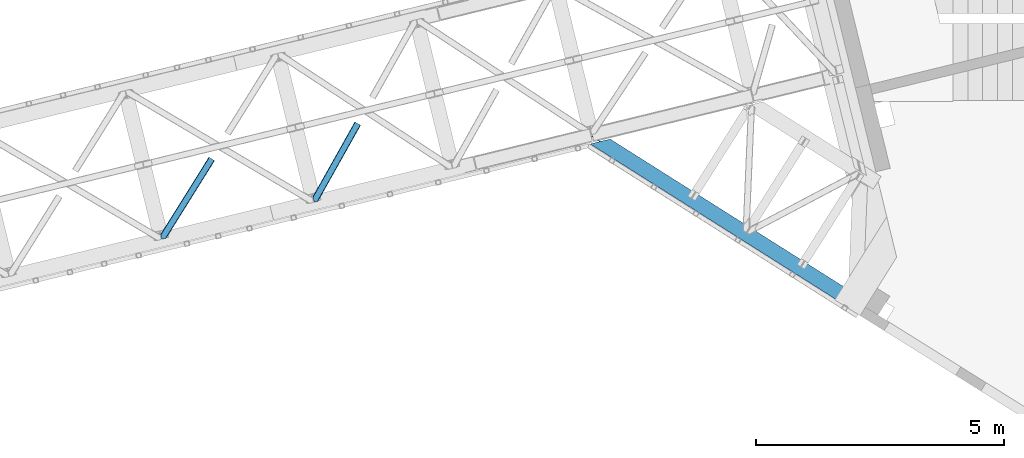
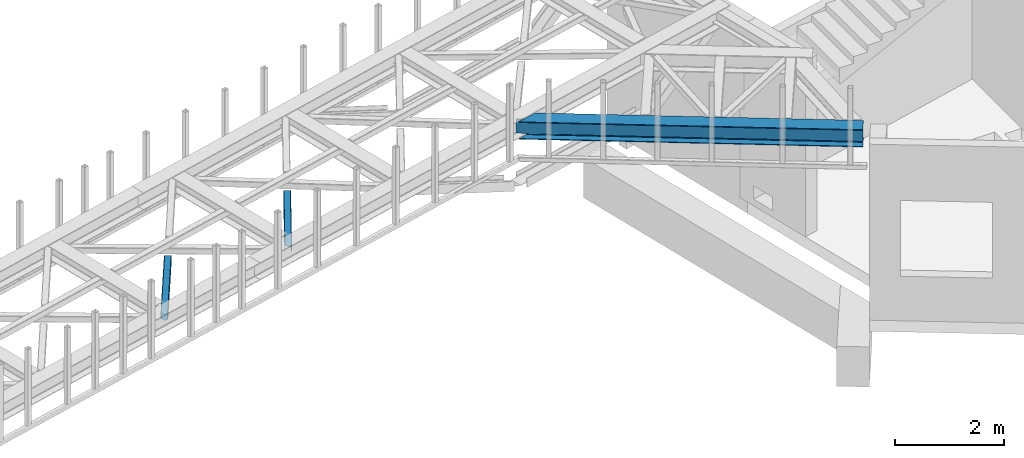
# One storey, part 48 of 66: 2 members, 1 beam.
"""IFC4 building model written with IfcOpenShell, lengths in millimetres."""

from ifc_helpers import new_model, entity, si_unit, converted_unit, derived_unit, direction, frame, origin, place, context, subcontext, project, spatial, triangles, polygons, material, type_object, element, save


model = new_model("IFC4")

# Units and contexts
model_context = context("Model", 3, precision=0.01, world=origin(), true_north=direction((6.12303176911189e-17, 1.0)))
plan_context = context("Plan", 3, precision=0.01, world=origin(), true_north=direction((6.12303176911189e-17, 1.0)))
body_context = subcontext(model_context, "Body", "Model", "MODEL_VIEW")
ifc_project = project(units=[si_unit("LENGTHUNIT", "METRE", prefix="MILLI"), si_unit("AREAUNIT", "SQUARE_METRE"), si_unit("VOLUMEUNIT", "CUBIC_METRE"), converted_unit("PLANEANGLEUNIT", "DEGREE", entity("IfcRatioMeasure", 0.0174532925199433), si_unit("PLANEANGLEUNIT", "RADIAN"), dimensions=[0, 0, 0, 0, 0, 0, 0]), si_unit("MASSUNIT", "GRAM", prefix="KILO"), derived_unit("MASSDENSITYUNIT", [(si_unit("MASSUNIT", "GRAM", prefix="KILO"), 1), (si_unit("LENGTHUNIT", "METRE"), -3)]), derived_unit("MOMENTOFINERTIAUNIT", [(si_unit("LENGTHUNIT", "METRE"), 4)]), si_unit("TIMEUNIT", "SECOND"), si_unit("FREQUENCYUNIT", "HERTZ"), si_unit("THERMODYNAMICTEMPERATUREUNIT", "DEGREE_CELSIUS"), derived_unit("THERMALTRANSMITTANCEUNIT", [(si_unit("MASSUNIT", "GRAM", prefix="KILO"), 1), (si_unit("THERMODYNAMICTEMPERATUREUNIT", "KELVIN"), -1), (si_unit("TIMEUNIT", "SECOND"), -3)]), derived_unit("VOLUMETRICFLOWRATEUNIT", [(si_unit("LENGTHUNIT", "METRE"), 3), (si_unit("TIMEUNIT", "SECOND"), -1)]), derived_unit("MASSFLOWRATEUNIT", [(si_unit("MASSUNIT", "GRAM", prefix="KILO"), 1), (si_unit("TIMEUNIT", "SECOND"), -1)]), derived_unit("ROTATIONALFREQUENCYUNIT", [(si_unit("TIMEUNIT", "SECOND"), -1)]), si_unit("ELECTRICCURRENTUNIT", "AMPERE"), si_unit("ELECTRICVOLTAGEUNIT", "VOLT"), si_unit("POWERUNIT", "WATT"), si_unit("FORCEUNIT", "NEWTON", prefix="KILO"), si_unit("ILLUMINANCEUNIT", "LUX"), si_unit("LUMINOUSFLUXUNIT", "LUMEN"), si_unit("LUMINOUSINTENSITYUNIT", "CANDELA"), derived_unit("USERDEFINED", [(si_unit("MASSUNIT", "GRAM", prefix="KILO"), -1), (si_unit("LENGTHUNIT", "METRE"), -2), (si_unit("TIMEUNIT", "SECOND"), 3), (si_unit("LUMINOUSFLUXUNIT", "LUMEN"), 1)]), derived_unit("LINEARVELOCITYUNIT", [(si_unit("LENGTHUNIT", "METRE"), 1), (si_unit("TIMEUNIT", "SECOND"), -1)]), si_unit("PRESSUREUNIT", "PASCAL"), derived_unit("USERDEFINED", [(si_unit("LENGTHUNIT", "METRE"), -2), (si_unit("MASSUNIT", "GRAM", prefix="KILO"), 1), (si_unit("TIMEUNIT", "SECOND"), -2)]), derived_unit("LINEARFORCEUNIT", [(si_unit("MASSUNIT", "GRAM", prefix="KILO"), 1), (si_unit("LENGTHUNIT", "METRE"), 1), (si_unit("TIMEUNIT", "SECOND"), -2), (si_unit("LENGTHUNIT", "METRE"), -1)]), derived_unit("PLANARFORCEUNIT", [(si_unit("MASSUNIT", "GRAM", prefix="KILO"), 1), (si_unit("LENGTHUNIT", "METRE"), 1), (si_unit("TIMEUNIT", "SECOND"), -2), (si_unit("LENGTHUNIT", "METRE"), -2)])], contexts=[model_context, plan_context])

# Site, building, storey
site_placement = place(None, origin())
site = spatial("IfcSite", under=ifc_project, at=site_placement, CompositionType="ELEMENT")
building_placement = place(site_placement, origin())
building = spatial("IfcBuilding", under=site, at=building_placement, CompositionType="ELEMENT")
storey_placement = place(building_placement, frame((0.0, 0.0, 19800.0)))
storey = spatial("IfcBuildingStorey", under=building, at=storey_placement, Name="06", CompositionType="ELEMENT", Elevation=19800.0)

# Beam
ifc_material = material(Name="Metal painted (White)")
beam_type = type_object("IfcBeamType", PredefinedType="BEAM")
beam_placement = place(storey_placement, frame((-5441.52, 12718.9, 3716.0)))
element("IfcBeam", 1, at=beam_placement, inside=storey, type_object=beam_type, material=ifc_material, ObjectType="Steel Beam", PredefinedType="BEAM", context=body_context, shape_type="Tessellation", body=[
    polygons([(5348.49662777212, 2.16573425859679e-12, 376.000000000005), (4.33146851719357e-12, 3381.27208353849, 376.000000000005), (165.112842431303, 3421.52008574059, 376.000000000005), (1093.62086845177, 2834.52555508644, 376.000000000005), (2173.67127244742, 2151.72727848622, 376.000000000005), (3253.72167644305, 1468.92900188599, 376.000000000005), (4333.77208043868, 786.130725285767, 376.000000000005), (5413.82248443432, 103.332448685544, 376.000000000005), (5348.49662777212, 2.16573425859679e-12, 392.000000000002), (4.33146851719357e-12, 3381.27208353849, 392.000000000002), (5508.8054784769, 253.576561191515, 392.000000000002), (405.184889401983, 3480.04018710194, 392.000000000002), (210.481526452577, 3432.57918246201, 355.999999999997), (194.703362949402, 3428.73308817842, 356.000000000001), (192.564591019406, 3428.21173989272, 362.419035512026), (186.123501179538, 3426.64165609887, 369.556349186104), (176.483729007347, 3424.29185964512, 374.325349715248), (405.18488940198, 3480.04018710194, 376.000000000001), (240.072046970671, 3439.79218489983, 376.000000000005), (228.701160394625, 3437.02041099531, 374.325349715248), (219.061388222436, 3434.67061454155, 369.556349186099), (212.620298382568, 3433.1005307477, 362.419035512026), (5348.49662777213, 2.16573425859679e-12, 0.0), (5508.8054784769, 253.576561191515, 0.0), (5508.8054784769, 253.576561191517, 15.9999999999964), (5443.4796218147, 150.244112505971, 15.9999999999964), (5438.98080212478, 143.127878927001, 17.6746502847538), (5435.16688695074, 137.095027401615, 22.4436508138939), (5432.61851030462, 133.064004886613, 29.5809644879676), (5431.72363942969, 131.648498018593, 38.0), (5431.72363942968, 131.648498018593, 354.000000000002), (5432.61851030462, 133.064004886613, 362.419035512026), (5435.16688695074, 137.095027401613, 369.556349186099), (5438.98080212478, 143.127878927001, 374.325349715248), (5443.4796218147, 150.244112505971, 376.000000000005), (5508.8054784769, 253.576561191517, 376.000000000001), (5418.32130412425, 110.448682264514, 374.325349715248), (5422.13521929827, 116.481533789893, 369.556349186104), (5424.6835959444, 120.512556304904, 362.419035512026), (5425.57846681934, 121.928063172921, 354.000000000002), (5425.57846681934, 121.928063172921, 38.0), (5424.6835959444, 120.512556304902, 29.5809644879676), (5422.13521929827, 116.481533789891, 22.4436508138939), (5418.32130412425, 110.448682264514, 17.6746502847452), (5413.82248443432, 103.332448685544, 16.0000000000007), (5348.49662777213, 2.16573425859679e-12, 15.9999999999964), (4539.61123918262, 721.661679363439, 376.000000000005), (3635.74285655055, 1293.0792462209, 376.000000000005), (2731.87447391849, 1864.49681307837, 376.000000000005), (1828.00609128641, 2435.91437993584, 376.000000000005), (924.137708654353, 3007.3319467933, 376.000000000005), (4344.63319194877, 803.310832905123, 362.41903551203), (4345.5280628237, 804.726339773147, 354.000000000002), (3264.58278795313, 1486.10910950535, 362.419035512026), (3265.47765882807, 1487.52461637337, 354.000000000002), (2184.5323839575, 2168.90738610558, 362.41903551203), (2185.42725483244, 2170.3228929736, 354.000000000002), (1104.48197996186, 2851.70566270579, 362.419035512034), (1105.3768508368, 2853.12116957382, 354.000000000002), (4342.08481530264, 799.279810390127, 369.556349186104), (3262.034411307, 1482.07808699035, 369.556349186104), (2181.98400731137, 2164.87636359058, 369.556349186104), (1101.93360331573, 2847.6746401908, 369.556349186104), (4338.27090012861, 793.246958864737, 374.325349715252), (3258.22049613296, 1476.04523546496, 374.325349715252), (2178.17009213734, 2158.84351206519, 374.325349715248), (1098.1196881417, 2841.64178866541, 374.325349715252), (25.277767615974, 3535.84244536922, 356.000000000001), (25.3283289836519, 3535.91175797538, 353.999999604166), (4535.11241949271, 714.545445784473, 374.325349715248), (3631.24403686065, 1285.96301264194, 374.325349715248), (2727.37565422857, 1857.3805794994, 374.325349715248), (1823.5072715965, 2428.79814635686, 374.325349715244), (919.638888964427, 3000.21571321434, 374.325349715248), (4531.29850431868, 708.512594259083, 369.556349186099), (3627.43012168661, 1279.93016111655, 369.556349186104), (2723.56173905454, 1851.34772797402, 369.556349186104), (1819.69335642247, 2422.76529483148, 369.556349186104), (915.824973790396, 2994.18286168895, 369.556349186104), (4528.75012767254, 704.481571744081, 362.41903551203), (3624.88174504048, 1275.89913860154, 362.41903551203), (2721.01336240841, 1847.31670545901, 362.419035512034), (1817.14497977633, 2418.73427231648, 362.41903551203), (913.276597144272, 2990.15183917395, 362.419035512034), (4527.85525679761, 703.066064876057, 354.000000000002), (3623.98687416554, 1274.48363173353, 354.000000000002), (2720.11849153348, 1845.90119859099, 354.000000000002), (1816.2501089014, 2417.31876544846, 354.000000000002), (912.381726269338, 2988.73633230592, 354.000000000002), (40.8590053356167, 3539.70363258882, 353.999999900932), (40.9815723062875, 3539.73554863413, 356.000000000001), (25.3276901044207, 3535.9143676771, 35.9999997385271), (25.3273911802177, 3535.91558872633, 37.9999998013935), (40.8572852816821, 3539.71065868616, 38.0000002626733), (40.9802875962089, 3539.74079643359, 36.0000002701888), (1105.37685083679, 2853.12116957382, 38.0), (2185.42725483242, 2170.3228929736, 38.0), (3265.47765882807, 1487.52461637337, 38.0), (4345.5280628237, 804.726339773145, 38.0), (4527.85525679762, 703.066064876057, 38.0), (3623.98687416554, 1274.48363173353, 38.0), (2720.11849153347, 1845.90119859099, 38.0), (1816.2501089014, 2417.31876544846, 38.0), (912.381726269339, 2988.73633230592, 38.0), (4338.27090012861, 793.246958864737, 17.6746502847452), (4333.77208043868, 786.130725285767, 16.0000000000007), (3258.22049613296, 1476.04523546496, 17.6746502847495), (3253.72167644305, 1468.92900188599, 16.000000000005), (2178.17009213734, 2158.84351206518, 17.6746502847495), (2173.67127244742, 2151.72727848622, 16.0000000000007), (1098.1196881417, 2841.64178866541, 17.6746502847495), (1093.62086845177, 2834.52555508644, 16.0000000000007), (4342.08481530264, 799.279810390123, 22.4436508138939), (3262.034411307, 1482.07808699035, 22.4436508138939), (2181.98400731137, 2164.87636359058, 22.4436508138982), (1101.93360331573, 2847.67464019079, 22.4436508138895), (4344.63319194876, 803.310832905125, 29.5809644879676), (3264.58278795312, 1486.10910950534, 29.5809644879676), (2184.5323839575, 2168.90738610557, 29.5809644879676), (1104.48197996185, 2851.70566270579, 29.5809644879676), (192.564591019411, 3428.21173989272, 29.5809644879676), (186.123501179543, 3426.64165609887, 22.4436508138939), (176.483729007351, 3424.29185964512, 17.6746502847495), (165.112842431302, 3421.52008574059, 16.0000000000007), (194.703362949402, 3428.73308817842, 36.0000000000005), (4.33146851719357e-12, 3381.27208353849, 16.0000000000007), (3.24860138789518e-12, 3381.27208353849, 0.0), (240.072046970672, 3439.79218489983, 15.9999999999964), (405.18488940198, 3480.04018710194, 15.9999999999964), (405.184889401981, 3480.04018710194, 0.0), (210.481526452582, 3432.57918246201, 36.0000000000005), (212.620298382576, 3433.1005307477, 29.5809644879676), (219.061388222445, 3434.67061454156, 22.4436508138939), (228.701160394625, 3437.02041099531, 17.6746502847495), (924.137708654352, 3007.3319467933, 16.0000000000007), (1828.00609128641, 2435.91437993584, 16.0000000000007), (2731.87447391849, 1864.49681307837, 16.0000000000007), (3635.74285655055, 1293.0792462209, 16.0000000000007), (4539.61123918262, 721.661679363439, 16.0000000000007), (4528.75012767254, 704.481571744079, 29.5809644879676), (3624.88174504048, 1275.89913860154, 29.5809644879676), (2721.01336240841, 1847.31670545901, 29.5809644879676), (1817.14497977633, 2418.73427231648, 29.5809644879719), (913.276597144274, 2990.15183917395, 29.5809644879676), (4531.29850431868, 708.512594259083, 22.4436508138939), (3627.43012168661, 1279.93016111655, 22.4436508138982), (2723.56173905453, 1851.34772797402, 22.4436508138939), (1819.69335642247, 2422.76529483147, 22.4436508138982), (915.824973790397, 2994.18286168895, 22.4436508138982), (4535.11241949271, 714.545445784471, 17.6746502847538), (3631.24403686065, 1285.96301264194, 17.6746502847495), (2727.37565422857, 1857.3805794994, 17.6746502847538), (1823.5072715965, 2428.79814635687, 17.6746502847538), (919.638888964427, 3000.21571321434, 17.6746502847495)], [[[1, 2, 3, 4, 5, 6, 7, 8]], [[9, 10, 2, 1]], [[11, 12, 10, 9]], [[13, 14, 15, 16, 17, 3, 2, 10, 12, 18, 19, 20, 21, 22]], [[23, 24, 25, 26, 27, 28, 29, 30, 31, 32, 33, 34, 35, 36, 11, 9, 1, 8, 37, 38, 39, 40, 41, 42, 43, 44, 45, 46]], [[36, 18, 12, 11]], [[35, 47, 48, 49, 50, 51, 19, 18, 36]], [[52, 53, 40, 39]], [[54, 55, 53, 52]], [[56, 57, 55, 54]], [[58, 59, 57, 56]], [[60, 52, 39, 38]], [[61, 54, 52, 60]], [[62, 56, 54, 61]], [[63, 58, 56, 62]], [[64, 60, 38, 37]], [[65, 61, 60, 64]], [[66, 62, 61, 65]], [[67, 63, 62, 66]], [[7, 64, 37, 8]], [[6, 65, 64, 7]], [[5, 66, 65, 6]], [[4, 67, 66, 5]], [[3, 17, 67, 4]], [[17, 16, 63, 67]], [[16, 15, 58, 63]], [[59, 14, 68, 69]], [[58, 14, 59]], [[14, 58, 15]], [[70, 47, 35, 34]], [[71, 48, 47, 70]], [[72, 49, 48, 71]], [[73, 50, 49, 72]], [[74, 51, 50, 73]], [[75, 70, 34, 33]], [[76, 71, 70, 75]], [[77, 72, 71, 76]], [[78, 73, 72, 77]], [[79, 74, 73, 78]], [[80, 75, 33, 32]], [[81, 76, 75, 80]], [[82, 77, 76, 81]], [[83, 78, 77, 82]], [[84, 79, 78, 83]], [[85, 80, 32, 31]], [[86, 81, 80, 85]], [[87, 82, 81, 86]], [[88, 83, 82, 87]], [[89, 84, 83, 88]], [[22, 21, 79, 84]], [[21, 20, 74, 79]], [[20, 19, 51, 74]], [[13, 90, 91]], [[84, 13, 22]], [[89, 13, 84]], [[13, 89, 90]], [[91, 68, 14, 13]], [[92, 93, 69, 68, 91, 90, 94, 95]], [[69, 93, 96, 97, 98, 99, 41, 40, 53, 55, 57, 59]], [[30, 100, 101, 102, 103, 104, 94, 90, 89, 88, 87, 86, 85, 31]], [[105, 106, 45, 44]], [[107, 108, 106, 105]], [[109, 110, 108, 107]], [[111, 112, 110, 109]], [[113, 105, 44, 43]], [[114, 107, 105, 113]], [[115, 109, 107, 114]], [[116, 111, 109, 115]], [[117, 113, 43, 42]], [[118, 114, 113, 117]], [[119, 115, 114, 118]], [[120, 116, 115, 119]], [[99, 117, 42, 41]], [[98, 118, 117, 99]], [[97, 119, 118, 98]], [[96, 120, 119, 97]], [[121, 122, 116, 120]], [[122, 123, 111, 116]], [[123, 124, 112, 111]], [[125, 93, 92]], [[120, 125, 121]], [[96, 125, 120]], [[125, 96, 93]], [[46, 126, 127, 23]], [[45, 106, 108, 110, 112, 124, 126, 46]], [[128, 129, 130, 127, 126, 124, 123, 122, 121, 125, 131, 132, 133, 134]], [[23, 127, 130, 24]], [[24, 130, 129, 25]], [[25, 129, 128, 135, 136, 137, 138, 139, 26]], [[140, 100, 30, 29]], [[141, 101, 100, 140]], [[142, 102, 101, 141]], [[143, 103, 102, 142]], [[144, 104, 103, 143]], [[145, 140, 29, 28]], [[146, 141, 140, 145]], [[147, 142, 141, 146]], [[148, 143, 142, 147]], [[149, 144, 143, 148]], [[150, 145, 28, 27]], [[151, 146, 145, 150]], [[152, 147, 146, 151]], [[153, 148, 147, 152]], [[154, 149, 148, 153]], [[139, 150, 27, 26]], [[138, 151, 150, 139]], [[137, 152, 151, 138]], [[136, 153, 152, 137]], [[135, 154, 153, 136]], [[128, 134, 154, 135]], [[134, 133, 149, 154]], [[133, 132, 144, 149]], [[104, 131, 95, 94]], [[104, 132, 131]], [[132, 104, 144]], [[131, 125, 92, 95]]], closed=True),
])

# Members
member_type_1 = type_object("IfcMemberType", PredefinedType="BRACE")
member_1_placement = place(storey_placement, frame((-11031.43, 14926.18, 3823.0)))
element("IfcMember", 2, at=member_1_placement, inside=storey, type_object=member_type_1, ObjectType="Steel Horizontal Brace", PredefinedType="BRACE", context=body_context, shape_type="Tessellation", body=[
    triangles([(967.681631469726, 1549.66471252442, 122.499499511719), (966.517749023436, 1550.31583557129, 129.196765136719), (108.48872680664, 19.7604217529297, 122.499499511719), (106.717904663084, 19.3290527343761, 129.196765136719), (963.210974121093, 1552.17386169434, 134.87548828125), (101.675189208983, 18.1000579833999, 134.87548828125), (958.258950805663, 1554.95276184082, 138.668280029298), (94.1337890625, 16.2617980957039, 138.668280029298), (952.418609619141, 1558.23279418945, 140.00075683594), (85.2320068359368, 14.0921630859375, 140.00075683594), (967.681631469726, 1549.66471252442, 17.5012573242202), (108.48872680664, 19.7604217529297, 17.5012573242202), (6.07521057128906, 87.5702362060547, 140.00075683594), (27.4215820312493, 0.0, 140.00075683594), (860.870709228515, 1609.64826049805, 140.00075683594), (855.030368041991, 1612.92713012695, 138.668280029298), (3.75093383788953, 97.1068634033218, 138.668280029298), (850.082995605468, 1615.70719299317, 134.87548828125), (1.7801239013661, 105.192416381837, 134.87548828125), (846.772732543945, 1617.56405639648, 129.196765136719), (0.46276245117042, 110.594412231447, 129.196765136719), (845.612338256835, 1618.21750488281, 122.499499511719), (0.0, 112.491970825196, 122.499499511719), (845.612338256835, 1618.21750488281, 17.5012573242202), (0.0, 112.491970825196, 17.5012573242202), (966.517749023436, 1550.31583557129, 10.8039916992202), (963.210974121093, 1552.17386169434, 5.12526855468968), (157.746185302734, 111.400177001953, 9.52034912109593), (158.140347290038, 112.965197753907, 8.76225585937573), (158.27173461914, 113.467492675782, 8.52041015625218), (157.353186035156, 117.235867309571, 5.12526855468968), (106.36094970703, 19.2418487548839, 10.8691040039084), (105.931906127929, 19.1372039794933, 9.52034912109593), (952.418609619141, 1558.23279418945, 0.0), (958.258950805663, 1554.95276184082, 1.33247680664135), (153.058099365233, 134.858047485352, 0.0), (155.382376098632, 125.321420288086, 1.33247680664135), (124.438916015624, 252.261346435547, 0.0), (94.4581878662102, 244.952490234376, 0.0), (860.870709228515, 1609.64826049805, 0.0), (153.051123046875, 130.664117431641, 9.52034912109593), (153.142977905272, 131.5815032959, 9.31571044922021), (153.232507324217, 132.509353637695, 9.1087463378899), (153.325524902342, 133.426739501954, 8.90410766601781), (152.944152832031, 135.321972656251, 8.42274169921802), (87.952770996093, 14.7549133300781, 9.52034912109593), (150.628015136717, 144.8272064209, 6.99957275390625), (124.438916015624, 252.261346435547, 6.99957275390625), (952.15816040039, 1558.38162231445, 8.3320495605476), (946.317819213866, 1561.66049194336, 6.99957275390625), (957.105532836913, 1555.60039672852, 12.1248413085959), (92.375756835936, 15.832754516603, 12.1248413085959), (961.576190185546, 1553.09124755859, 24.5008300781265), (960.415795898436, 1553.7435333252, 17.8035644531265), (99.1858062744141, 17.4931182861328, 24.5008300781265), (97.4138214111317, 17.0617492675792, 17.8035644531265), (103.762271118163, 247.220956420899, 6.99957275390625), (866.972662353515, 1606.21940002442, 6.99957275390625), (85.5610565185543, 242.784017944337, 1.33247680664135), (91.7385864257813, 244.289739990236, 9.52034912109593), (78.0161682128892, 240.944595336914, 5.12526855468968), (95.0593139648427, 245.098992919922, 8.82504272460938), (73.7641021728505, 239.908612060548, 9.52034912109593), (846.772732543945, 1617.56405639648, 10.8039916992202), (4.59390563964735, 117.490502929688, 10.8714294433594), (850.082995605468, 1615.70719299317, 5.12526855468968), (5.69267578124891, 118.696243286133, 9.52034912109593), (855.030368041991, 1612.92713012695, 1.33247680664135), (0.0104644775383349, 112.452438354492, 16.5199218750022), (10.3889007568359, 99.4323028564468, 9.52034912109593), (7.36001586914063, 100.839193725587, 12.1248413085959), (3.09864807128906, 99.7811187744155, 16.5199218750022), (852.878173828125, 1614.13752136231, 17.8035644531265), (851.714291381835, 1614.78864440918, 24.5008300781265), (2.43008422851563, 102.522811889648, 24.5008300781265), (2.98586425781104, 100.243881225586, 17.8686767578147), (856.183786010741, 1612.27949523926, 12.1248413085959), (861.136972045897, 1609.49943237305, 8.3320495605476), (961.576190185546, 1553.09124755859, 115.499926757813), (99.1858062744141, 17.4931182861328, 115.499926757813), (97.4138214111317, 17.0617492675792, 122.197192382813), (84.8297058105454, 13.9933319091797, 131.668707275392), (75.9325744628895, 11.8248596191406, 133.001184082033), (27.4215820312493, 0.0, 133.001184082033), (92.375756835936, 15.832754516603, 127.873590087893), (946.317819213866, 1561.66049194336, 133.001184082033), (952.15816040039, 1558.38162231445, 131.668707275392), (957.105532836913, 1555.60039672852, 127.873590087893), (960.415795898436, 1553.7435333252, 122.197192382813), (856.183786010741, 1612.27949523926, 127.873590087893), (866.972662353515, 1606.21940002442, 133.001184082033), (861.136972045897, 1609.49943237305, 131.668707275392), (851.714291381835, 1614.78864440918, 115.499926757813), (852.878173828125, 1614.13752136231, 122.197192382813), (6.18101806640516, 87.1388671875011, 131.668707275392), (8.50529479980469, 77.6010772705085, 133.001184082033), (4.21020812988172, 95.2232574462905, 127.873590087893), (2.43008422851563, 102.522811889648, 115.499926757813), (2.89284667968604, 100.626416015626, 122.197192382813)], [[1, 2, 3], [4, 3, 2], [2, 5, 4], [6, 4, 5], [5, 7, 6], [8, 6, 7], [7, 9, 8], [10, 8, 9], [11, 1, 3], [3, 12, 11], [13, 10, 9], [10, 13, 14], [9, 15, 13], [15, 16, 17], [17, 13, 15], [16, 18, 19], [19, 17, 16], [18, 20, 21], [21, 19, 18], [20, 22, 23], [23, 21, 20], [22, 24, 25], [25, 23, 22], [26, 11, 12], [27, 28, 29], [30, 31, 27], [26, 32, 28], [28, 27, 26], [32, 33, 28], [34, 35, 36], [37, 36, 35], [35, 27, 37], [31, 37, 27], [12, 32, 26], [38, 39, 40], [36, 38, 34], [40, 34, 38], [41, 42, 28], [42, 43, 29], [43, 44, 29], [44, 45, 30], [33, 46, 28], [41, 28, 46], [45, 47, 36], [38, 47, 48], [47, 38, 36], [45, 31, 30], [45, 36, 37], [37, 31, 45], [49, 50, 47], [51, 49, 45], [45, 44, 51], [51, 43, 42], [43, 51, 44], [42, 41, 51], [51, 41, 52], [46, 52, 41], [47, 45, 49], [53, 54, 55], [56, 55, 54], [54, 51, 56], [52, 56, 51], [48, 47, 50], [57, 48, 58], [50, 58, 48], [59, 60, 61], [57, 38, 48], [57, 62, 39], [57, 39, 38], [39, 60, 59], [61, 60, 63], [62, 60, 39], [24, 64, 65], [65, 25, 24], [65, 64, 63], [64, 66, 61], [61, 63, 64], [63, 67, 65], [66, 68, 59], [59, 61, 66], [68, 40, 39], [39, 59, 68], [65, 69, 25], [65, 70, 71], [65, 67, 70], [71, 69, 65], [72, 69, 71], [70, 67, 60], [63, 60, 67], [73, 74, 75], [73, 72, 71], [73, 76, 72], [77, 71, 60], [60, 78, 77], [60, 62, 78], [71, 70, 60], [78, 62, 57], [57, 58, 78], [71, 77, 73], [75, 76, 73], [79, 53, 55], [55, 80, 79], [81, 3, 4], [82, 8, 10], [14, 83, 10], [83, 14, 84], [83, 82, 10], [85, 8, 82], [85, 81, 6], [6, 8, 85], [4, 6, 81], [55, 12, 3], [52, 33, 56], [81, 80, 3], [52, 46, 33], [55, 56, 12], [80, 55, 3], [32, 12, 56], [56, 33, 32], [86, 87, 82], [82, 83, 86], [87, 88, 85], [85, 82, 87], [88, 89, 81], [81, 85, 88], [89, 79, 80], [80, 81, 89], [26, 51, 54], [53, 1, 11], [26, 54, 11], [26, 27, 51], [54, 53, 11], [51, 27, 35], [50, 34, 40], [34, 49, 35], [49, 34, 50], [49, 51, 35], [2, 88, 5], [79, 1, 53], [1, 89, 2], [89, 1, 79], [2, 89, 88], [9, 86, 15], [7, 5, 88], [88, 87, 7], [87, 86, 9], [9, 7, 87], [77, 68, 66], [40, 58, 50], [40, 78, 58], [78, 40, 68], [77, 78, 68], [74, 24, 22], [64, 73, 77], [66, 64, 77], [73, 64, 24], [74, 73, 24], [16, 90, 18], [15, 86, 91], [91, 92, 15], [92, 90, 16], [16, 15, 92], [20, 18, 90], [22, 93, 74], [94, 22, 20], [22, 94, 93], [94, 20, 90], [95, 96, 13], [96, 14, 13], [96, 84, 14], [17, 95, 13], [97, 17, 19], [97, 95, 17], [72, 76, 69], [23, 98, 99], [99, 19, 21], [19, 99, 97], [21, 23, 99], [23, 75, 98], [25, 69, 76], [25, 75, 23], [75, 25, 76], [83, 96, 86], [83, 84, 96], [91, 86, 96], [74, 93, 75], [98, 75, 93], [93, 94, 98], [99, 98, 94], [94, 90, 99], [97, 99, 90], [90, 92, 97], [95, 97, 92], [92, 91, 95], [96, 95, 91]]),
])
member_type_2 = type_object("IfcMemberType", PredefinedType="BRACE")
member_2_placement = place(storey_placement, frame((-14098.67, 14177.81, 3823.0)))
element("IfcMember", 3, at=member_2_placement, inside=storey, type_object=member_type_2, ObjectType="Steel Horizontal Brace", PredefinedType="BRACE", context=body_context, shape_type="Tessellation", body=[
    triangles([(986.151434326172, 1647.42967529297, 0.0), (1075.22041625976, 1591.82725524902, 0.0), (119.789199829102, 259.603921508789, 0.0), (154.549868774413, 117.004486083984, 0.0), (115.90339050293, 275.545971679687, 4.52065429687718), (117.571893310547, 268.699877929686, 1.33247680664135), (158.435678100586, 101.063598632813, 4.52065429687718), (156.766012573242, 107.909692382813, 1.33247680664135), (114.825549316405, 275.743634033202, 5.52059326172093), (115.131344604491, 275.92385559082, 5.35316162109302), (158.132208251953, 99.1230194091786, 5.27642211914281), (115.440628051758, 276.108728027344, 5.18107910156323), (158.235690307616, 99.7787933349609, 5.02062377929906), (158.189181518554, 99.4822998046875, 5.13457031250073), (115.540621948241, 276.168026733398, 5.12526855468968), (115.687124633789, 275.922692871094, 4.88574829101708), (158.339172363281, 100.434567260741, 4.76482543945531), (158.032214355468, 98.4939880371094, 5.52059326172093), (1085.71744995117, 1585.27416687012, 5.12526855468968), (1080.90146484375, 1588.28096008301, 1.33247680664135), (1088.9358581543, 1583.26614990234, 10.8039916992202), (114.209307861327, 21.8533172607422, 10.8039916992202), (109.470062255859, 20.697573852538, 5.52059326172093), (1090.06485900879, 1582.56037902832, 17.5012573242202), (116.062683105469, 22.3044525146488, 17.5012573242202), (6.75075073242078, 102.619317626953, 5.52059326172093), (31.3620391845707, 1.65803833007703, 5.52059326172093), (1090.06485900879, 1582.56037902832, 122.499499511719), (116.062683105469, 22.3044525146488, 122.499499511719), (1088.9358581543, 1583.26614990234, 129.196765136719), (114.209307861327, 21.8533172607422, 129.196765136719), (1085.71744995117, 1585.27416687012, 134.87548828125), (108.936373901366, 20.5673492431633, 134.87548828125), (1080.90146484375, 1588.28096008301, 138.668280029298), (101.042669677734, 18.6430480957024, 138.668280029298), (1075.22041625976, 1591.82725524902, 140.00075683594), (91.7292846679684, 16.3734191894528, 140.00075683594), (980.470385742186, 1650.97597045899, 1.33247680664135), (975.654400634765, 1653.98276367187, 5.12526855468968), (1.68826904296839, 100.41131286621, 10.9621215820334), (972.43599243164, 1655.99194335938, 10.8039916992202), (971.306991577148, 1656.69655151367, 17.5012573242202), (0.239520263670784, 99.7787933349609, 12.5201660156272), (0.0, 100.761291503906, 17.5012573242202), (5.79266967773401, 76.9941375732415, 140.00075683594), (986.151434326172, 1647.42967529297, 140.00075683594), (24.5612915039055, 0.0, 140.00075683594), (971.306991577148, 1656.69655151367, 122.499499511719), (0.0, 100.761291503906, 122.499499511719), (980.470385742186, 1650.97597045899, 138.668280029298), (3.57652587890516, 86.088931274413, 138.668280029298), (975.654400634765, 1653.98276367187, 134.87548828125), (1.69640808105396, 93.8000885009769, 134.87548828125), (972.43599243164, 1655.99194335938, 129.196765136719), (0.44067077636646, 98.9520996093743, 129.196765136719), (29.9249176025387, 1.30805969238281, 6.99957275390625), (12.1969299316406, 74.0338531494144, 6.99957275390625), (8.9959625244137, 81.5496734619137, 8.3320495605476), (3.8869720458988, 84.8122650146488, 12.5201660156272), (1069.28589477539, 1595.53516845703, 6.99957275390625), (81.996157836913, 14.0014709472653, 6.99957275390625), (992.090606689453, 1643.72292480469, 6.99957275390625), (981.593572998047, 1650.27601318359, 12.1248413085959), (978.376327514648, 1652.28519287109, 17.8035644531265), (2.75797119140589, 89.4457031250004, 17.8035644531265), (986.410720825195, 1647.2692199707, 8.3320495605476), (977.24616394043, 1652.99096374512, 24.5008300781265), (2.31730041503943, 91.2548950195305, 24.5008300781265), (977.24616394043, 1652.99096374512, 115.499926757813), (2.31730041503943, 91.2548950195305, 115.499926757813), (4.01370849609339, 84.2936920166012, 127.873590087893), (2.75797119140589, 89.4457031250004, 122.197192382813), (5.89382629394458, 76.5825347900391, 131.668707275392), (8.10997009277344, 67.4877410888676, 133.001184082033), (24.5612915039055, 0.0, 133.001184082033), (978.376327514648, 1652.28519287109, 122.197192382813), (981.593572998047, 1650.27601318359, 127.873590087893), (986.410720825195, 1647.2692199707, 131.668707275392), (992.090606689453, 1643.72292480469, 133.001184082033), (1069.28589477539, 1595.53516845703, 133.001184082033), (81.996157836913, 14.0014709472653, 133.001184082033), (1079.78176574707, 1588.98208007813, 12.1248413085959), (1083.00017395019, 1586.97290039063, 17.8035644531265), (1084.13033752441, 1586.2671295166, 24.5008300781265), (1074.96578063965, 1591.98887329101, 8.3320495605476), (1079.78176574707, 1588.98208007813, 127.873590087893), (1084.13033752441, 1586.2671295166, 115.499926757813), (1083.00017395019, 1586.97290039063, 122.197192382813), (1074.96578063965, 1591.98887329101, 131.668707275392), (91.3095428466786, 16.2710998535149, 131.668707275392), (99.2032470703125, 18.1954010009758, 127.873590087893), (104.476181030273, 19.4802062988274, 122.197192382813), (106.329556274413, 19.9325042724613, 115.499926757813), (91.3095428466786, 16.2710998535149, 8.3320495605476), (104.476181030273, 19.4802062988274, 17.8035644531265), (99.2032470703125, 18.1954010009758, 12.1248413085959), (106.329556274413, 19.9325042724613, 24.5008300781265)], [[1, 2, 3], [4, 3, 2], [5, 3, 4], [3, 5, 6], [4, 7, 5], [7, 4, 8], [9, 10, 11], [10, 12, 13], [13, 14, 10], [12, 15, 16], [16, 17, 12], [16, 5, 7], [7, 17, 16], [17, 13, 12], [14, 11, 10], [11, 18, 9], [19, 14, 13], [13, 20, 19], [13, 17, 20], [17, 7, 20], [7, 8, 20], [21, 22, 18], [18, 19, 21], [14, 19, 11], [18, 11, 19], [22, 23, 18], [21, 24, 25], [25, 22, 21], [2, 20, 4], [8, 4, 20], [23, 26, 18], [23, 27, 26], [9, 18, 26], [24, 28, 29], [29, 25, 24], [28, 30, 29], [31, 29, 30], [30, 32, 31], [33, 31, 32], [32, 34, 33], [35, 33, 34], [34, 36, 35], [37, 35, 36], [38, 6, 5], [5, 39, 38], [39, 5, 16], [16, 15, 39], [40, 41, 9], [41, 39, 15], [15, 12, 41], [12, 9, 41], [42, 41, 40], [40, 43, 42], [43, 44, 42], [9, 26, 40], [38, 1, 6], [3, 6, 1], [36, 45, 37], [36, 46, 45], [45, 47, 37], [48, 42, 44], [44, 49, 48], [46, 50, 51], [51, 45, 46], [50, 52, 53], [53, 51, 50], [52, 54, 55], [55, 53, 52], [54, 48, 49], [49, 55, 54], [27, 56, 57], [26, 57, 58], [57, 26, 27], [59, 40, 26], [26, 58, 59], [43, 40, 59], [60, 57, 61], [60, 62, 57], [57, 56, 61], [63, 64, 65], [65, 59, 63], [66, 63, 59], [62, 66, 58], [58, 57, 62], [59, 58, 66], [64, 67, 68], [68, 65, 64], [67, 69, 70], [70, 68, 67], [71, 53, 72], [73, 74, 45], [74, 47, 45], [74, 75, 47], [51, 73, 45], [71, 51, 53], [71, 73, 51], [49, 68, 70], [55, 72, 53], [70, 72, 49], [72, 55, 49], [44, 68, 49], [43, 59, 65], [65, 68, 44], [44, 43, 65], [69, 76, 70], [72, 70, 76], [76, 77, 72], [71, 72, 77], [77, 78, 71], [73, 71, 78], [78, 79, 73], [74, 73, 79], [80, 74, 79], [74, 80, 81], [75, 74, 81], [21, 82, 83], [84, 28, 24], [21, 83, 24], [21, 19, 82], [83, 84, 24], [82, 19, 20], [60, 2, 1], [2, 85, 20], [85, 2, 60], [85, 82, 20], [30, 86, 32], [87, 28, 84], [28, 88, 30], [88, 28, 87], [30, 88, 86], [36, 80, 46], [34, 32, 86], [86, 89, 34], [89, 80, 36], [36, 34, 89], [63, 38, 39], [1, 62, 60], [1, 66, 62], [66, 1, 38], [63, 66, 38], [67, 42, 48], [41, 64, 63], [39, 41, 63], [64, 41, 42], [67, 64, 42], [50, 77, 52], [46, 80, 79], [79, 78, 46], [78, 77, 50], [50, 46, 78], [54, 52, 77], [48, 69, 67], [76, 48, 54], [48, 76, 69], [76, 54, 77], [35, 37, 90], [47, 81, 37], [81, 47, 75], [81, 90, 37], [91, 35, 90], [91, 33, 35], [33, 92, 31], [92, 33, 91], [29, 92, 93], [92, 29, 31], [61, 23, 94], [95, 96, 23], [96, 94, 23], [61, 27, 23], [27, 61, 56], [97, 95, 25], [22, 25, 95], [29, 97, 25], [97, 29, 93], [95, 23, 22], [80, 89, 90], [90, 81, 80], [89, 86, 91], [91, 90, 89], [86, 88, 92], [92, 91, 86], [88, 87, 93], [93, 92, 88], [87, 84, 97], [97, 93, 87], [84, 83, 97], [95, 97, 83], [83, 82, 95], [96, 95, 82], [82, 85, 96], [94, 96, 85], [85, 60, 94], [61, 94, 60]]),
])

save(model, "model.ifc")
